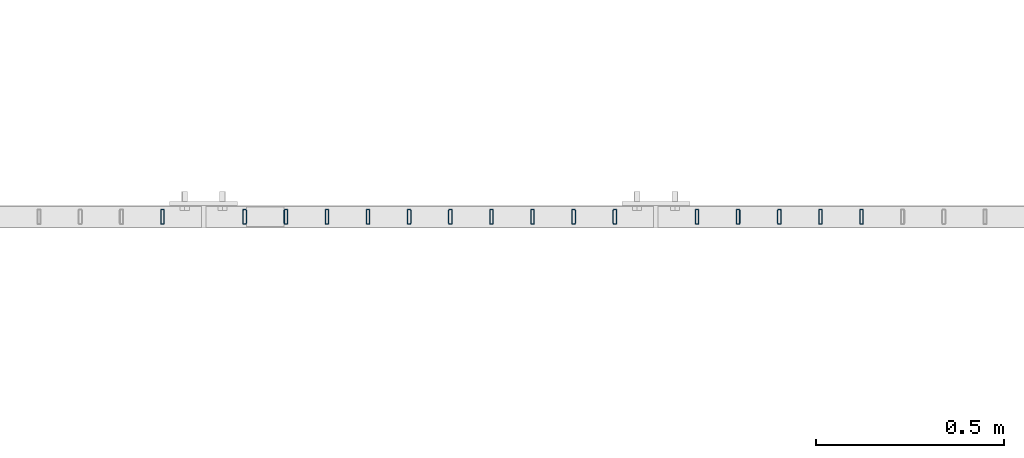
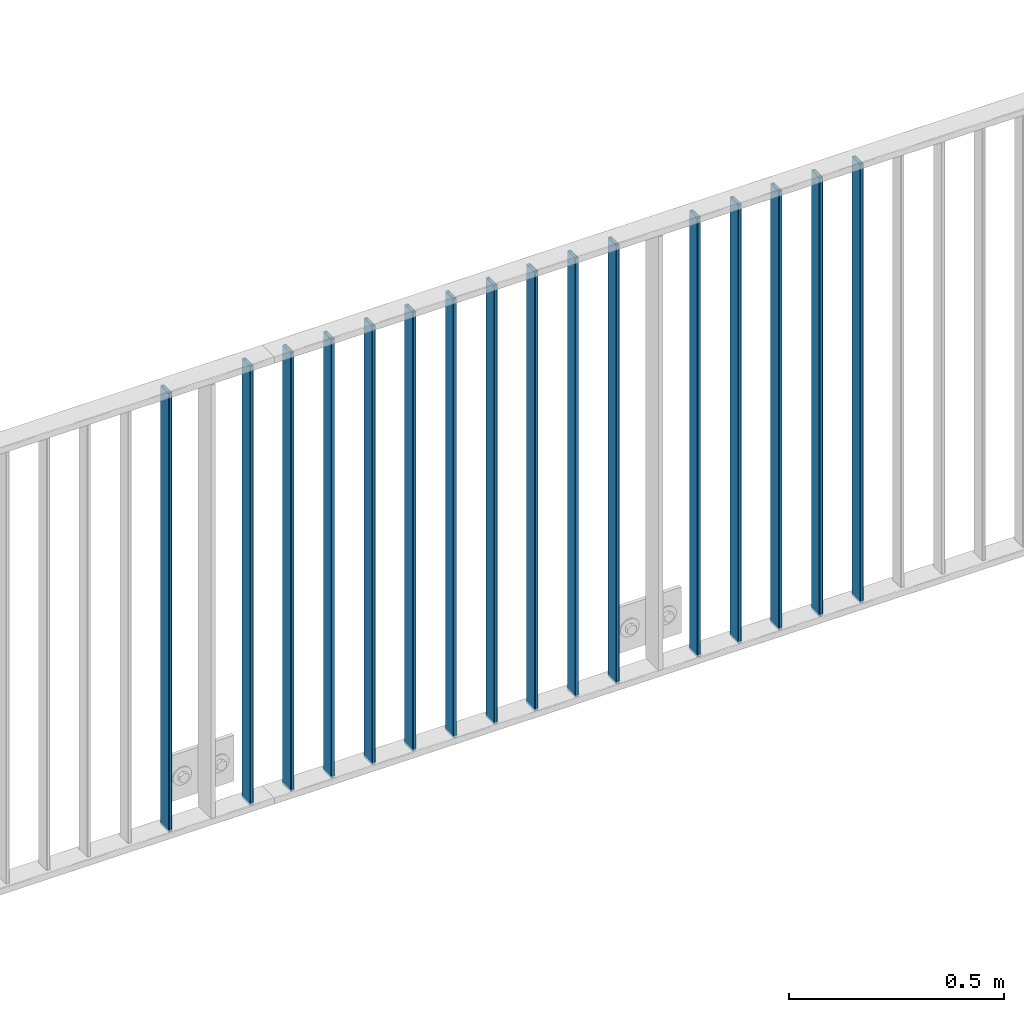
# One storey, part 8 of 156: 16 beams, 2 elements without a shape of their own.
"""IFC2X3 building model written with IfcOpenShell, lengths in millimetres."""

from ifc_helpers import new_model, si_unit, frame, origin_with_axes, origin_2d_with_axis, place, context, subcontext, project, spatial, hollow_rectangle, extrude, clip, halfspace, material, type_object, element, aggregate, save


model = new_model("IFC2X3")

# Units and contexts
model_context = context("Model", 3, precision=1e-05, world=origin_with_axes())
body_context = subcontext(model_context, "Body", "Model", "MODEL_VIEW")
ifc_project = project(units=[si_unit("LENGTHUNIT", "METRE", prefix="MILLI"), si_unit("AREAUNIT", "SQUARE_METRE"), si_unit("VOLUMEUNIT", "CUBIC_METRE"), si_unit("MASSUNIT", "GRAM", prefix="KILO"), si_unit("TIMEUNIT", "SECOND"), si_unit("PLANEANGLEUNIT", "RADIAN"), si_unit("SOLIDANGLEUNIT", "STERADIAN"), si_unit("THERMODYNAMICTEMPERATUREUNIT", "DEGREE_CELSIUS"), si_unit("LUMINOUSINTENSITYUNIT", "LUMEN")], contexts=[model_context])

# Site, building, storey
site_placement = place(None, origin_with_axes())
site = spatial("IfcSite", under=ifc_project, at=site_placement, CompositionType="ELEMENT")
building_placement = place(site_placement, origin_with_axes())
building = spatial("IfcBuilding", under=site, at=building_placement, Name="Undefined", CompositionType="ELEMENT")
storey_placement = place(building_placement, origin_with_axes())
storey = spatial("IfcBuildingStorey", under=building, at=storey_placement, Name="Undefined", CompositionType="ELEMENT", Elevation=0.0)

# Assembly, beams
assembly_1_placement = place(storey_placement, origin_with_axes())
assembly_1 = element("IfcElementAssembly", 1, at=assembly_1_placement, inside=storey, AssemblyPlace="NOTDEFINED", PredefinedType="RIGID_FRAME")
ifc_material = material(Name="STEEL/S235JR")
beam_type = type_object("IfcBeamType", Name="K40/10/1.5", PredefinedType="NOTDEFINED")
beam_1_placement = place(assembly_1_placement, frame((23145.449999999, 10879.9998088346, 3980.00000000003), z_axis=(0.0, 1.0, 0.0), x_axis=(0.0, 0.0, -1.0)))
beam_1 = element("IfcBeam", 2, at=beam_1_placement, type_object=beam_type, material=ifc_material, ObjectType="K40/10/1.5", context=body_context, shape_type="Clipping", body=[
    clip(clip(extrude(hollow_rectangle(XDim=10.0, YDim=40.0, WallThickness=1.5, InnerFilletRadius=1.5, OuterFilletRadius=3.0, at=origin_2d_with_axis()), frame((1237.00000000003, 0.0, 0.0), z_axis=(-1.0, 0.0, 0.0), x_axis=(0.0, -1.0, 0.0)), (0.0, 0.0, 1.0), 1244.0), halfspace(frame((1237.00000000003, 4.34248751949781, 47.3810900558092), z_axis=(1.0, 0.0, 0.0), x_axis=(0.0, -0.768354814194188, -0.640024124158313)), False)), halfspace(frame((-6.99999999997453, -4.34248751950508, 47.3810900558092), z_axis=(-1.0, 0.0, 0.0), x_axis=(0.0, 0.763991285051099, -0.645226562043109)), False)),
])
beam_2_placement = place(assembly_1_placement, frame((23036.359999999, 10879.9998088346, 3980.00000000003), z_axis=(0.0, 1.0, 0.0), x_axis=(0.0, 0.0, -1.0)))
beam_2 = element("IfcBeam", 3, at=beam_2_placement, type_object=beam_type, material=ifc_material, ObjectType="K40/10/1.5", context=body_context, shape_type="Clipping", body=[
    clip(clip(extrude(hollow_rectangle(XDim=10.0, YDim=40.0, WallThickness=1.5, InnerFilletRadius=1.5, OuterFilletRadius=3.0, at=origin_2d_with_axis()), frame((1237.00000000003, 0.0, 0.0), z_axis=(-1.0, 0.0, 0.0), x_axis=(0.0, -1.0, 0.0)), (0.0, 0.0, 1.0), 1244.0), halfspace(frame((1237.00000000003, 4.34248751949781, 47.3810900558092), z_axis=(1.0, 0.0, 0.0), x_axis=(0.0, -0.768354814194188, -0.640024124158313)), False)), halfspace(frame((-6.99999999997453, -4.34248751950508, 47.3810900558092), z_axis=(-1.0, 0.0, 0.0), x_axis=(0.0, 0.763991285051099, -0.645226562043109)), False)),
])
beam_3_placement = place(assembly_1_placement, frame((22927.269999999, 10879.9998088346, 3980.00000000003), z_axis=(0.0, 1.0, 0.0), x_axis=(0.0, 0.0, -1.0)))
beam_3 = element("IfcBeam", 4, at=beam_3_placement, type_object=beam_type, material=ifc_material, ObjectType="K40/10/1.5", context=body_context, shape_type="Clipping", body=[
    clip(clip(extrude(hollow_rectangle(XDim=10.0, YDim=40.0, WallThickness=1.5, InnerFilletRadius=1.5, OuterFilletRadius=3.0, at=origin_2d_with_axis()), frame((1237.00000000003, 0.0, 0.0), z_axis=(-1.0, 0.0, 0.0), x_axis=(0.0, -1.0, 0.0)), (0.0, 0.0, 1.0), 1244.0), halfspace(frame((1237.00000000003, 4.34248751949781, 47.3810900558092), z_axis=(1.0, 0.0, 0.0), x_axis=(0.0, -0.768354814194188, -0.640024124158313)), False)), halfspace(frame((-6.99999999997453, -4.34248751950508, 47.3810900558092), z_axis=(-1.0, 0.0, 0.0), x_axis=(0.0, 0.763991285051099, -0.645226562043109)), False)),
])
beam_4_placement = place(assembly_1_placement, frame((22818.179999999, 10879.9998088346, 3980.00000000003), z_axis=(0.0, 1.0, 0.0), x_axis=(0.0, 0.0, -1.0)))
beam_4 = element("IfcBeam", 5, at=beam_4_placement, type_object=beam_type, material=ifc_material, ObjectType="K40/10/1.5", context=body_context, shape_type="Clipping", body=[
    clip(clip(extrude(hollow_rectangle(XDim=10.0, YDim=40.0, WallThickness=1.5, InnerFilletRadius=1.5, OuterFilletRadius=3.0, at=origin_2d_with_axis()), frame((1237.00000000003, 0.0, 0.0), z_axis=(-1.0, 0.0, 0.0), x_axis=(0.0, -1.0, 0.0)), (0.0, 0.0, 1.0), 1244.0), halfspace(frame((1237.00000000003, 4.34248751949781, 47.3810900558092), z_axis=(1.0, 0.0, 0.0), x_axis=(0.0, -0.768354814194188, -0.640024124158313)), False)), halfspace(frame((-6.99999999997453, -4.34248751950508, 47.3810900558092), z_axis=(-1.0, 0.0, 0.0), x_axis=(0.0, 0.763991285051099, -0.645226562043109)), False)),
])
beam_5_placement = place(assembly_1_placement, frame((22709.089999999, 10879.9998088346, 3980.00000000003), z_axis=(0.0, 1.0, 0.0), x_axis=(0.0, 0.0, -1.0)))
beam_5 = element("IfcBeam", 6, at=beam_5_placement, type_object=beam_type, material=ifc_material, ObjectType="K40/10/1.5", context=body_context, shape_type="Clipping", body=[
    clip(clip(extrude(hollow_rectangle(XDim=10.0, YDim=40.0, WallThickness=1.5, InnerFilletRadius=1.5, OuterFilletRadius=3.0, at=origin_2d_with_axis()), frame((1237.00000000003, 0.0, 0.0), z_axis=(-1.0, 0.0, 0.0), x_axis=(0.0, -1.0, 0.0)), (0.0, 0.0, 1.0), 1244.0), halfspace(frame((1237.00000000003, 4.34248751949781, 47.3810900558092), z_axis=(1.0, 0.0, 0.0), x_axis=(0.0, -0.766598961667631, -0.642126180723158)), False)), halfspace(frame((-6.99999999997453, -4.28697690345871, 47.3348312091512), z_axis=(-1.0, 0.0, 0.0), x_axis=(0.0, 0.763991285051099, -0.645226562043109)), False)),
])
beam_6_placement = place(assembly_1_placement, frame((22490.899999999, 10879.9998088346, 3980.00000000003), z_axis=(0.0, 1.0, 0.0), x_axis=(0.0, 0.0, -1.0)))
beam_6 = element("IfcBeam", 7, at=beam_6_placement, type_object=beam_type, material=ifc_material, ObjectType="K40/10/1.5", context=body_context, shape_type="Clipping", body=[
    clip(clip(extrude(hollow_rectangle(XDim=10.0, YDim=40.0, WallThickness=1.5, InnerFilletRadius=1.5, OuterFilletRadius=3.0, at=origin_2d_with_axis()), frame((1237.00000000003, 0.0, 0.0), z_axis=(-1.0, 0.0, 0.0), x_axis=(0.0, -1.0, 0.0)), (0.0, 0.0, 1.0), 1244.0), halfspace(frame((1237.00000000003, 4.34248751949781, 47.3810900558092), z_axis=(1.0, 0.0, 0.0), x_axis=(0.0, -0.768354814194188, -0.640024124158313)), False)), halfspace(frame((-6.99999999997453, -4.34248751950508, 47.3810900558092), z_axis=(-1.0, 0.0, 0.0), x_axis=(0.0, 0.763991285051099, -0.645226562043109)), False)),
])
beam_7_placement = place(assembly_1_placement, frame((22381.809999999, 10879.9998088346, 3980.00000000003), z_axis=(0.0, 1.0, 0.0), x_axis=(0.0, 0.0, -1.0)))
beam_7 = element("IfcBeam", 8, at=beam_7_placement, type_object=beam_type, material=ifc_material, ObjectType="K40/10/1.5", context=body_context, shape_type="Clipping", body=[
    clip(clip(extrude(hollow_rectangle(XDim=10.0, YDim=40.0, WallThickness=1.5, InnerFilletRadius=1.5, OuterFilletRadius=3.0, at=origin_2d_with_axis()), frame((1237.00000000003, 0.0, 0.0), z_axis=(-1.0, 0.0, 0.0), x_axis=(0.0, -1.0, 0.0)), (0.0, 0.0, 1.0), 1244.0), halfspace(frame((1237.00000000003, 4.34248751949781, 47.3810900558092), z_axis=(1.0, 0.0, 0.0), x_axis=(0.0, -0.768354814194188, -0.640024124158313)), False)), halfspace(frame((-6.99999999997453, -4.34248751950508, 47.3810900558092), z_axis=(-1.0, 0.0, 0.0), x_axis=(0.0, 0.763991285051099, -0.645226562043109)), False)),
])
beam_8_placement = place(assembly_1_placement, frame((22272.719999999, 10879.9998088346, 3980.00000000003), z_axis=(0.0, 1.0, 0.0), x_axis=(0.0, 0.0, -1.0)))
beam_8 = element("IfcBeam", 9, at=beam_8_placement, type_object=beam_type, material=ifc_material, ObjectType="K40/10/1.5", context=body_context, shape_type="Clipping", body=[
    clip(clip(extrude(hollow_rectangle(XDim=10.0, YDim=40.0, WallThickness=1.5, InnerFilletRadius=1.5, OuterFilletRadius=3.0, at=origin_2d_with_axis()), frame((1237.00000000003, 0.0, 0.0), z_axis=(-1.0, 0.0, 0.0), x_axis=(0.0, -1.0, 0.0)), (0.0, 0.0, 1.0), 1244.0), halfspace(frame((1237.00000000003, 4.34248751949781, 47.3810900558092), z_axis=(1.0, 0.0, 0.0), x_axis=(0.0, -0.768354814194188, -0.640024124158313)), False)), halfspace(frame((-6.99999999997453, -4.34248751950508, 47.3810900558092), z_axis=(-1.0, 0.0, 0.0), x_axis=(0.0, 0.763991285051099, -0.645226562043109)), False)),
])
beam_9_placement = place(assembly_1_placement, frame((22163.629999999, 10879.9998088346, 3980.00000000003), z_axis=(0.0, 1.0, 0.0), x_axis=(0.0, 0.0, -1.0)))
beam_9 = element("IfcBeam", 10, at=beam_9_placement, type_object=beam_type, material=ifc_material, ObjectType="K40/10/1.5", context=body_context, shape_type="Clipping", body=[
    clip(clip(extrude(hollow_rectangle(XDim=10.0, YDim=40.0, WallThickness=1.5, InnerFilletRadius=1.5, OuterFilletRadius=3.0, at=origin_2d_with_axis()), frame((1237.00000000003, 0.0, 0.0), z_axis=(-1.0, 0.0, 0.0), x_axis=(0.0, -1.0, 0.0)), (0.0, 0.0, 1.0), 1244.0), halfspace(frame((1237.00000000003, 4.34248751949781, 47.3810900558092), z_axis=(1.0, 0.0, 0.0), x_axis=(0.0, -0.768354814194188, -0.640024124158313)), False)), halfspace(frame((-6.99999999997453, -4.34248751950508, 47.3810900558092), z_axis=(-1.0, 0.0, 0.0), x_axis=(0.0, 0.763991285051099, -0.645226562043109)), False)),
])
beam_10_placement = place(assembly_1_placement, frame((22054.539999999, 10879.9998088346, 3980.00000000003), z_axis=(0.0, 1.0, 0.0), x_axis=(0.0, 0.0, -1.0)))
beam_10 = element("IfcBeam", 11, at=beam_10_placement, type_object=beam_type, material=ifc_material, ObjectType="K40/10/1.5", context=body_context, shape_type="Clipping", body=[
    clip(clip(extrude(hollow_rectangle(XDim=10.0, YDim=40.0, WallThickness=1.5, InnerFilletRadius=1.5, OuterFilletRadius=3.0, at=origin_2d_with_axis()), frame((1237.00000000003, 0.0, 0.0), z_axis=(-1.0, 0.0, 0.0), x_axis=(0.0, -1.0, 0.0)), (0.0, 0.0, 1.0), 1244.0), halfspace(frame((1237.00000000003, 4.34248751949781, 47.3810900558092), z_axis=(1.0, 0.0, 0.0), x_axis=(0.0, -0.768354814194188, -0.640024124158313)), False)), halfspace(frame((-6.99999999997453, -4.34248751950508, 47.3810900558092), z_axis=(-1.0, 0.0, 0.0), x_axis=(0.0, 0.763991285051099, -0.645226562043109)), False)),
])
beam_11_placement = place(assembly_1_placement, frame((21945.449999999, 10879.9998088346, 3980.00000000003), z_axis=(0.0, 1.0, 0.0), x_axis=(0.0, 0.0, -1.0)))
beam_11 = element("IfcBeam", 12, at=beam_11_placement, type_object=beam_type, material=ifc_material, ObjectType="K40/10/1.5", context=body_context, shape_type="Clipping", body=[
    clip(clip(extrude(hollow_rectangle(XDim=10.0, YDim=40.0, WallThickness=1.5, InnerFilletRadius=1.5, OuterFilletRadius=3.0, at=origin_2d_with_axis()), frame((1237.00000000003, 0.0, 0.0), z_axis=(-1.0, 0.0, 0.0), x_axis=(0.0, -1.0, 0.0)), (0.0, 0.0, 1.0), 1244.0), halfspace(frame((1237.00000000003, 4.34248751949781, 47.3810900558092), z_axis=(1.0, 0.0, 0.0), x_axis=(0.0, -0.768354814194188, -0.640024124158313)), False)), halfspace(frame((-6.99999999997453, -4.34248751950508, 47.3810900558092), z_axis=(-1.0, 0.0, 0.0), x_axis=(0.0, 0.763991285051099, -0.645226562043109)), False)),
])
beam_12_placement = place(assembly_1_placement, frame((21836.359999999, 10879.9998088346, 3980.00000000003), z_axis=(0.0, 1.0, 0.0), x_axis=(0.0, 0.0, -1.0)))
beam_12 = element("IfcBeam", 13, at=beam_12_placement, type_object=beam_type, material=ifc_material, ObjectType="K40/10/1.5", context=body_context, shape_type="Clipping", body=[
    clip(clip(extrude(hollow_rectangle(XDim=10.0, YDim=40.0, WallThickness=1.5, InnerFilletRadius=1.5, OuterFilletRadius=3.0, at=origin_2d_with_axis()), frame((1237.00000000003, 0.0, 0.0), z_axis=(-1.0, 0.0, 0.0), x_axis=(0.0, -1.0, 0.0)), (0.0, 0.0, 1.0), 1244.0), halfspace(frame((1237.00000000003, 4.34248751949781, 47.3810900558092), z_axis=(1.0, 0.0, 0.0), x_axis=(0.0, -0.768354814194188, -0.640024124158313)), False)), halfspace(frame((-6.99999999997453, -4.34248751950508, 47.3810900558092), z_axis=(-1.0, 0.0, 0.0), x_axis=(0.0, 0.763991285051099, -0.645226562043109)), False)),
])
beam_13_placement = place(assembly_1_placement, frame((21727.269999999, 10879.9998088346, 3980.00000000003), z_axis=(0.0, 1.0, 0.0), x_axis=(0.0, 0.0, -1.0)))
beam_13 = element("IfcBeam", 14, at=beam_13_placement, type_object=beam_type, material=ifc_material, ObjectType="K40/10/1.5", context=body_context, shape_type="Clipping", body=[
    clip(clip(extrude(hollow_rectangle(XDim=10.0, YDim=40.0, WallThickness=1.5, InnerFilletRadius=1.5, OuterFilletRadius=3.0, at=origin_2d_with_axis()), frame((1237.00000000003, 0.0, 0.0), z_axis=(-1.0, 0.0, 0.0), x_axis=(0.0, -1.0, 0.0)), (0.0, 0.0, 1.0), 1244.0), halfspace(frame((1237.00000000003, 4.34248751949781, 47.3810900558092), z_axis=(1.0, 0.0, 0.0), x_axis=(0.0, -0.768354814194188, -0.640024124158313)), False)), halfspace(frame((-6.99999999997453, -4.34248751950508, 47.3810900558092), z_axis=(-1.0, 0.0, 0.0), x_axis=(0.0, 0.763991285051099, -0.645226562043109)), False)),
])
beam_14_placement = place(assembly_1_placement, frame((21618.179999999, 10879.9998088346, 3980.00000000003), z_axis=(0.0, 1.0, 0.0), x_axis=(0.0, 0.0, -1.0)))
beam_14 = element("IfcBeam", 15, at=beam_14_placement, type_object=beam_type, material=ifc_material, ObjectType="K40/10/1.5", context=body_context, shape_type="Clipping", body=[
    clip(clip(extrude(hollow_rectangle(XDim=10.0, YDim=40.0, WallThickness=1.5, InnerFilletRadius=1.5, OuterFilletRadius=3.0, at=origin_2d_with_axis()), frame((1237.00000000003, 0.0, 0.0), z_axis=(-1.0, 0.0, 0.0), x_axis=(0.0, -1.0, 0.0)), (0.0, 0.0, 1.0), 1244.0), halfspace(frame((1237.00000000003, 4.34248751949781, 47.3810900558092), z_axis=(1.0, 0.0, 0.0), x_axis=(0.0, -0.768354814194188, -0.640024124158313)), False)), halfspace(frame((-6.99999999997453, -4.34248751950508, 47.3810900558092), z_axis=(-1.0, 0.0, 0.0), x_axis=(0.0, 0.763991285051099, -0.645226562043109)), False)),
])
aggregate(assembly_1, [beam_1, beam_2, beam_3, beam_4, beam_5, beam_6, beam_7, beam_8, beam_9, beam_10, beam_11, beam_12, beam_13, beam_14])

assembly_2_placement = place(storey_placement, origin_with_axes())
assembly_2 = element("IfcElementAssembly", 16, at=assembly_2_placement, inside=storey, AssemblyPlace="NOTDEFINED", PredefinedType="RIGID_FRAME")
beam_15_placement = place(assembly_2_placement, frame((21509.089999999, 10879.9998088346, 3980.00000000003), z_axis=(0.0, 1.0, 0.0), x_axis=(0.0, 0.0, -1.0)))
beam_15 = element("IfcBeam", 17, at=beam_15_placement, type_object=beam_type, material=ifc_material, ObjectType="K40/10/1.5", context=body_context, shape_type="Clipping", body=[
    clip(clip(extrude(hollow_rectangle(XDim=10.0, YDim=40.0, WallThickness=1.5, InnerFilletRadius=1.5, OuterFilletRadius=3.0, at=origin_2d_with_axis()), frame((1237.00000000003, 0.0, 0.0), z_axis=(-1.0, 0.0, 0.0), x_axis=(0.0, -1.0, 0.0)), (0.0, 0.0, 1.0), 1244.0), halfspace(frame((1237.00000000003, 3.90376720472705, 47.0154897941684), z_axis=(1.0, 0.0, 0.0), x_axis=(0.0, -0.761952806119621, -0.647632551101653)), False)), halfspace(frame((-6.99999999997453, -3.24498419219526, 46.4665039507308), z_axis=(-1.0, 0.0, 0.0), x_axis=(0.0, 0.75441426312288, -0.656398598106944)), False)),
])
beam_16_placement = place(assembly_2_placement, frame((21290.899999999, 10879.9998088346, 3980.00000000003), z_axis=(0.0, 1.0, 0.0), x_axis=(0.0, 0.0, -1.0)))
beam_16 = element("IfcBeam", 18, at=beam_16_placement, type_object=beam_type, material=ifc_material, ObjectType="K40/10/1.5", context=body_context, shape_type="Clipping", body=[
    clip(clip(extrude(hollow_rectangle(XDim=10.0, YDim=40.0, WallThickness=1.5, InnerFilletRadius=1.5, OuterFilletRadius=3.0, at=origin_2d_with_axis()), frame((1237.00000000003, 0.0, 0.0), z_axis=(-1.0, 0.0, 0.0), x_axis=(0.0, -1.0, 0.0)), (0.0, 0.0, 1.0), 1244.0), halfspace(frame((1237.00000000003, 4.28697690345871, 47.3348312091512), z_axis=(1.0, 0.0, 0.0), x_axis=(0.0, -0.763991285051099, -0.645226562043109)), False)), halfspace(frame((-6.99999999997453, -4.08341515816574, 47.1651964219527), z_axis=(-1.0, 0.0, 0.0), x_axis=(0.0, 0.763991285051099, -0.645226562043109)), False)),
])
aggregate(assembly_2, [beam_15, beam_16])

save(model, "model.ifc")
